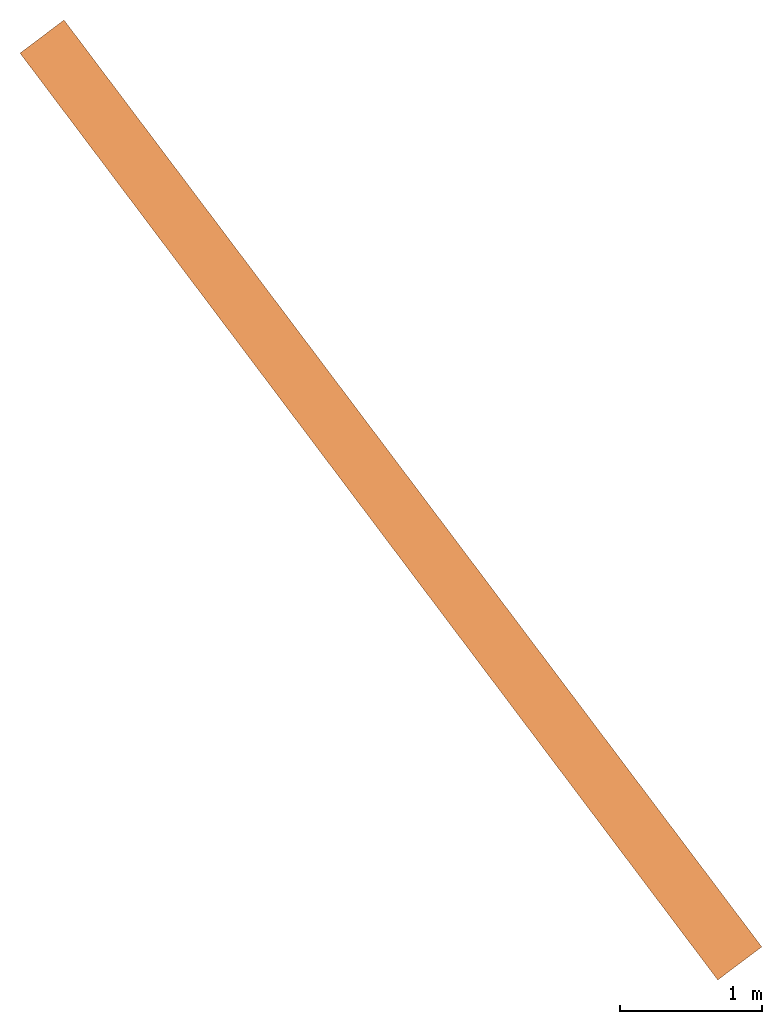
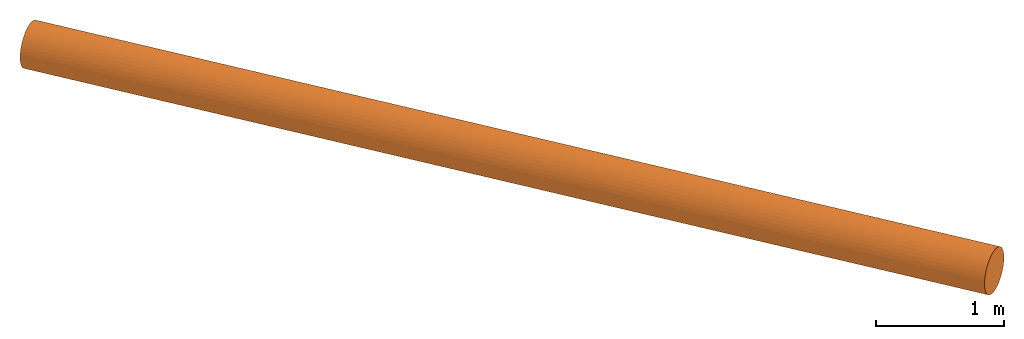
"""IFC2X3 building model written with IfcOpenShell, lengths in metres."""

from ifc_helpers import new_model, entity, si_unit, converted_unit, direction, frame, origin_with_axes, place, context, project, spatial, faceted_brep, element, save


model = new_model("IFC2X3")

# Units and contexts
model_context = context("Model", 3, precision=1e-05, world=origin_with_axes(), true_north=direction((0.0, 1.0)))
ifc_project = project(units=[si_unit("LENGTHUNIT", "METRE"), converted_unit("PLANEANGLEUNIT", "Degree", entity("IfcPlaneAngleMeasure", 0.015707963), si_unit("PLANEANGLEUNIT", "RADIAN"), dimensions=[0, 0, 0, 0, 0, 0, 0]), si_unit("AREAUNIT", "SQUARE_METRE"), si_unit("VOLUMEUNIT", "CUBIC_METRE"), si_unit("MASSUNIT", "GRAM", prefix="KILO")], contexts=[model_context])

# Site, building, storeys
site_placement = place(None, frame((0.0, 0.0, 0.0), z_axis=(0.0, 0.0, 1.0), x_axis=(1.0, 6.12323399573677e-17, 0.0)))
site = spatial("IfcSite", under=ifc_project, at=site_placement, CompositionType="ELEMENT")
building_placement = place(None, frame((0.0, 0.0, 0.0), z_axis=(0.0, 0.0, 1.0), x_axis=(1.0, 6.12323399573677e-17, 0.0)))
building = spatial("IfcBuilding", under=site, at=building_placement, Name="(G0) Grupo 0", CompositionType="ELEMENT")
storey_1_placement = place(building_placement, origin_with_axes())
storey_1 = spatial("IfcBuildingStorey", under=building, at=storey_1_placement, Name="(E2)", CompositionType="ELEMENT")
storey_2_placement = place(storey_1_placement, origin_with_axes())
storey_2 = spatial("IfcBuildingStorey", under=storey_1, at=storey_2_placement, CompositionType="PARTIAL")
storey_3_placement = place(storey_2_placement, origin_with_axes())
storey_3 = spatial("IfcBuildingStorey", under=storey_2, at=storey_3_placement, Name="TUBO", CompositionType="PARTIAL")

# Proxy
proxy_placement = place(storey_3_placement, frame((9.057202, -3.186392, 174.6203), z_axis=(0.0, 0.0, 1.0), x_axis=(1.0, 0.0, 0.0)))
element("IfcBuildingElementProxy", 1, at=proxy_placement, inside=storey_3, Name="TUBO 1", ObjectType="TUBO", CompositionType="ELEMENT", context=model_context, shape_type="Brep", body=[
    faceted_brep([(5.068858, 0.116682, 0.4697), (5.068258, 0.117482, 0.4697), (5.092465, 0.135706, 0.4673), (5.093065, 0.134906, 0.4673), (5.116113, 0.153509, 0.4602), (5.116713, 0.152709, 0.4602), (5.138642, 0.17047, 0.4486), (5.139242, 0.16967, 0.4486), (5.159334, 0.186048, 0.4326), (5.159934, 0.185248, 0.4327), (5.177868, 0.200001, 0.4129), (5.178468, 0.199201, 0.4129), (5.193607, 0.21185, 0.3897), (5.194207, 0.21105, 0.3897), (5.206389, 0.221473, 0.3638), (5.206989, 0.220673, 0.3638), (5.215657, 0.22845, 0.3356), (5.216257, 0.22765, 0.3357), (5.221329, 0.23272, 0.306), (5.221929, 0.23192, 0.3061), (5.223246, 0.234164, 0.2757), (5.223846, 0.233364, 0.2757), (4.91387, 0.0, 0.2757), (4.91327, 0.0008, 0.2757), (4.915187, 0.002243, 0.306), (4.915787, 0.001443, 0.3061), (4.92086, 0.006514, 0.3356), (4.92146, 0.005714, 0.3357), (4.930127, 0.013491, 0.3638), (4.930727, 0.012691, 0.3638), (4.942909, 0.023114, 0.3897), (4.943509, 0.022314, 0.3897), (4.958648, 0.034963, 0.4129), (4.959248, 0.034163, 0.4129), (4.977183, 0.048916, 0.4326), (4.977783, 0.048116, 0.4327), (4.997874, 0.064494, 0.4486), (4.998474, 0.063694, 0.4486), (5.020404, 0.081455, 0.4602), (5.021004, 0.080655, 0.4602), (5.044051, 0.099258, 0.4673), (5.044651, 0.098458, 0.4673), (5.221329, 0.23272, 0.2453), (5.221929, 0.23192, 0.2454), (5.215657, 0.22845, 0.2157), (5.216257, 0.22765, 0.2158), (5.206389, 0.221473, 0.1876), (5.206989, 0.220673, 0.1876), (5.193607, 0.21185, 0.1617), (5.194207, 0.21105, 0.1617), (5.177868, 0.200001, 0.1385), (5.178468, 0.199201, 0.1385), (5.159334, 0.186048, 0.1187), (5.159934, 0.185248, 0.1188), (5.138642, 0.17047, 0.1028), (5.139242, 0.16967, 0.1028), (5.116113, 0.153509, 0.0912), (5.116713, 0.152709, 0.0912), (5.092465, 0.135706, 0.0841), (5.093065, 0.134906, 0.0841), (5.068258, 0.117482, 0.0817), (5.068858, 0.116682, 0.0817), (5.044051, 0.099258, 0.0841), (5.044651, 0.098458, 0.0841), (5.020404, 0.081455, 0.0912), (5.021004, 0.080655, 0.0912), (4.997874, 0.064494, 0.1028), (4.998474, 0.063694, 0.1028), (4.977183, 0.048916, 0.1187), (4.977783, 0.048116, 0.1188), (4.958648, 0.034963, 0.1385), (4.959248, 0.034163, 0.1385), (4.942909, 0.023114, 0.1617), (4.943509, 0.022314, 0.1617), (4.930127, 0.013491, 0.1876), (4.930727, 0.012691, 0.1876), (4.92086, 0.006514, 0.2157), (4.92146, 0.005714, 0.2158), (4.915187, 0.002243, 0.2453), (4.915787, 0.001443, 0.2454), (0.155588, 6.642962, 0.388), (0.179795, 6.661186, 0.3856), (0.203443, 6.678989, 0.3785), (0.225972, 6.69595, 0.3669), (0.246664, 6.711528, 0.351), (0.265198, 6.725481, 0.3312), (0.280937, 6.73733, 0.308), (0.293719, 6.746953, 0.2821), (0.302987, 6.75393, 0.254), (0.308659, 6.7582, 0.2244), (0.310576, 6.759644, 0.194), (0.0006, 6.52628, 0.194), (0.002517, 6.527723, 0.2244), (0.00819, 6.531994, 0.254), (0.017457, 6.538971, 0.2821), (0.030239, 6.548594, 0.308), (0.045978, 6.560443, 0.3312), (0.064513, 6.574396, 0.351), (0.085204, 6.589974, 0.3669), (0.107734, 6.606935, 0.3785), (0.131381, 6.624738, 0.3856), (0.308659, 6.7582, 0.1637), (0.302987, 6.75393, 0.1341), (0.293719, 6.746953, 0.1059), (0.280937, 6.73733, 0.08), (0.265198, 6.725481, 0.0568), (0.246664, 6.711528, 0.0371), (0.225972, 6.69595, 0.0211), (0.203443, 6.678989, 0.0095), (0.179795, 6.661186, 0.0024), (0.155588, 6.642962, 0.0), (0.131381, 6.624738, 0.0024), (0.107734, 6.606935, 0.0095), (0.085204, 6.589974, 0.0211), (0.064513, 6.574396, 0.0371), (0.045978, 6.560443, 0.0568), (0.030239, 6.548594, 0.08), (0.017457, 6.538971, 0.1059), (0.00819, 6.531994, 0.1341), (0.002517, 6.527723, 0.1637), (0.154988, 6.643762, 0.388), (0.179195, 6.661986, 0.3856), (0.202843, 6.679789, 0.3785), (0.225372, 6.69675, 0.3669), (0.246064, 6.712328, 0.351), (0.264598, 6.726281, 0.3312), (0.280337, 6.73813, 0.308), (0.293119, 6.747753, 0.2821), (0.302387, 6.75473, 0.254), (0.308059, 6.759, 0.2244), (0.309976, 6.760444, 0.194), (0.0, 6.52708, 0.194), (0.001917, 6.528523, 0.2244), (0.00759, 6.532794, 0.254), (0.016857, 6.539771, 0.2821), (0.029639, 6.549394, 0.308), (0.045378, 6.561243, 0.3312), (0.063913, 6.575196, 0.351), (0.084604, 6.590774, 0.3669), (0.107134, 6.607735, 0.3785), (0.130781, 6.625538, 0.3856), (0.308059, 6.759, 0.1637), (0.302387, 6.75473, 0.134), (0.293119, 6.747753, 0.1059), (0.280337, 6.73813, 0.08), (0.264598, 6.726281, 0.0568), (0.246064, 6.712328, 0.037), (0.225372, 6.69675, 0.0211), (0.202843, 6.679789, 0.0095), (0.179195, 6.661986, 0.0024), (0.154988, 6.643762, 0.0), (0.130781, 6.625538, 0.0024), (0.107134, 6.607735, 0.0095), (0.084604, 6.590774, 0.0211), (0.063913, 6.575196, 0.037), (0.045378, 6.561243, 0.0568), (0.029639, 6.549394, 0.08), (0.016857, 6.539771, 0.1059), (0.00759, 6.532794, 0.134), (0.001917, 6.528523, 0.1637)], [[[0, 1, 2, 3]], [[3, 2, 4, 5]], [[5, 4, 6, 7]], [[7, 6, 8, 9]], [[9, 8, 10, 11]], [[11, 10, 12, 13]], [[13, 12, 14, 15]], [[15, 14, 16, 17]], [[17, 16, 18, 19]], [[19, 18, 20, 21]], [[22, 23, 24, 25]], [[25, 24, 26, 27]], [[27, 26, 28, 29]], [[29, 28, 30, 31]], [[31, 30, 32, 33]], [[33, 32, 34, 35]], [[35, 34, 36, 37]], [[37, 36, 38, 39]], [[39, 38, 40, 41]], [[41, 40, 1, 0]], [[21, 20, 42, 43]], [[43, 42, 44, 45]], [[45, 44, 46, 47]], [[47, 46, 48, 49]], [[49, 48, 50, 51]], [[51, 50, 52, 53]], [[53, 52, 54, 55]], [[55, 54, 56, 57]], [[57, 56, 58, 59]], [[59, 58, 60, 61]], [[61, 60, 62, 63]], [[63, 62, 64, 65]], [[65, 64, 66, 67]], [[67, 66, 68, 69]], [[69, 68, 70, 71]], [[71, 70, 72, 73]], [[73, 72, 74, 75]], [[75, 74, 76, 77]], [[77, 76, 78, 79]], [[79, 78, 23, 22]], [[1, 80, 81, 2]], [[2, 81, 82, 4]], [[4, 82, 83, 6]], [[6, 83, 84, 8]], [[8, 84, 85, 10]], [[10, 85, 86, 12]], [[12, 86, 87, 14]], [[14, 87, 88, 16]], [[16, 88, 89, 18]], [[18, 89, 90, 20]], [[23, 91, 92, 24]], [[24, 92, 93, 26]], [[26, 93, 94, 28]], [[28, 94, 95, 30]], [[30, 95, 96, 32]], [[32, 96, 97, 34]], [[34, 97, 98, 36]], [[36, 98, 99, 38]], [[38, 99, 100, 40]], [[40, 100, 80, 1]], [[20, 90, 101, 42]], [[42, 101, 102, 44]], [[44, 102, 103, 46]], [[46, 103, 104, 48]], [[48, 104, 105, 50]], [[50, 105, 106, 52]], [[52, 106, 107, 54]], [[54, 107, 108, 56]], [[56, 108, 109, 58]], [[58, 109, 110, 60]], [[60, 110, 111, 62]], [[62, 111, 112, 64]], [[64, 112, 113, 66]], [[66, 113, 114, 68]], [[68, 114, 115, 70]], [[70, 115, 116, 72]], [[72, 116, 117, 74]], [[74, 117, 118, 76]], [[76, 118, 119, 78]], [[78, 119, 91, 23]], [[80, 120, 121, 81]], [[81, 121, 122, 82]], [[82, 122, 123, 83]], [[83, 123, 124, 84]], [[84, 124, 125, 85]], [[85, 125, 126, 86]], [[86, 126, 127, 87]], [[87, 127, 128, 88]], [[88, 128, 129, 89]], [[89, 129, 130, 90]], [[91, 131, 132, 92]], [[92, 132, 133, 93]], [[93, 133, 134, 94]], [[94, 134, 135, 95]], [[95, 135, 136, 96]], [[96, 136, 137, 97]], [[97, 137, 138, 98]], [[98, 138, 139, 99]], [[99, 139, 140, 100]], [[100, 140, 120, 80]], [[90, 130, 141, 101]], [[101, 141, 142, 102]], [[102, 142, 143, 103]], [[103, 143, 144, 104]], [[104, 144, 145, 105]], [[105, 145, 146, 106]], [[106, 146, 147, 107]], [[107, 147, 148, 108]], [[108, 148, 149, 109]], [[109, 149, 150, 110]], [[110, 150, 151, 111]], [[111, 151, 152, 112]], [[112, 152, 153, 113]], [[113, 153, 154, 114]], [[114, 154, 155, 115]], [[115, 155, 156, 116]], [[116, 156, 157, 117]], [[117, 157, 158, 118]], [[118, 158, 159, 119]], [[119, 159, 131, 91]], [[79, 31, 73]], [[75, 77, 73]], [[73, 77, 79]], [[71, 73, 69]], [[53, 69, 73]], [[67, 69, 65]], [[65, 69, 63]], [[49, 73, 31]], [[69, 59, 63]], [[79, 22, 25]], [[31, 27, 29]], [[27, 31, 25]], [[25, 31, 79]], [[31, 33, 35]], [[39, 35, 37]], [[39, 31, 35]], [[41, 31, 39]], [[13, 31, 41]], [[61, 63, 59]], [[57, 59, 53]], [[73, 49, 53]], [[57, 53, 55]], [[53, 49, 51]], [[47, 49, 45]], [[43, 49, 13]], [[49, 43, 45]], [[13, 49, 31]], [[21, 43, 19]], [[7, 9, 5]], [[13, 3, 5]], [[13, 5, 9]], [[41, 0, 3]], [[17, 19, 13]], [[11, 13, 9]], [[17, 13, 15]], [[3, 13, 41]], [[19, 43, 13]], [[59, 69, 53]], [[156, 135, 159]], [[156, 158, 157]], [[159, 158, 156]], [[154, 156, 155]], [[144, 135, 156]], [[152, 154, 153]], [[156, 152, 151]], [[156, 154, 152]], [[149, 156, 151]], [[132, 131, 159]], [[134, 133, 135]], [[132, 135, 133]], [[159, 135, 132]], [[137, 136, 135]], [[138, 137, 139]], [[137, 135, 139]], [[139, 135, 140]], [[140, 135, 126]], [[149, 151, 150]], [[148, 144, 149]], [[144, 148, 146]], [[147, 146, 148]], [[146, 145, 144]], [[142, 144, 143]], [[126, 144, 141]], [[142, 141, 144]], [[135, 144, 126]], [[141, 130, 129]], [[122, 124, 123]], [[122, 121, 126]], [[124, 122, 126]], [[121, 120, 140]], [[126, 129, 128]], [[124, 126, 125]], [[127, 126, 128]], [[140, 126, 121]], [[126, 141, 129]], [[156, 149, 144]]], orient=[[False], [False], [False], [False], [False], [False], [False], [False], [False], [False], [False], [False], [False], [False], [False], [False], [False], [False], [False], [False], [False], [False], [False], [False], [False], [False], [False], [False], [False], [False], [False], [False], [False], [False], [False], [False], [False], [False], [False], [False], [False], [False], [False], [False], [False], [False], [False], [False], [False], [False], [False], [False], [False], [False], [False], [False], [False], [False], [False], [False], [False], [False], [False], [False], [False], [False], [False], [False], [False], [False], [False], [False], [False], [False], [False], [False], [False], [False], [False], [False], [False], [False], [False], [False], [False], [False], [False], [False], [False], [False], [False], [False], [False], [False], [False], [False], [False], [False], [False], [False], [False], [False], [False], [False], [False], [False], [False], [False], [False], [False], [False], [False], [False], [False], [False], [False], [False], [False], [False], [False], [False], [False], [False], [False], [False], [False], [False], [False], [False], [False], [False], [False], [False], [False], [False], [False], [False], [False], [False], [False], [False], [False], [False], [False], [False], [False], [False], [False], [False], [False], [False], [False], [False], [False], [False], [False], [False], [False], [False], [False], [False], [False], [False], [False], [False], [False], [False], [False], [False], [False], [False], [False], [False], [False], [False], [False], [False], [False], [False], [False], [False], [False], [False], [False], [False], [False], [False], [False], [False], [False], [False], [False], [False], [False], [False], [False]]),
])

save(model, "model.ifc")
